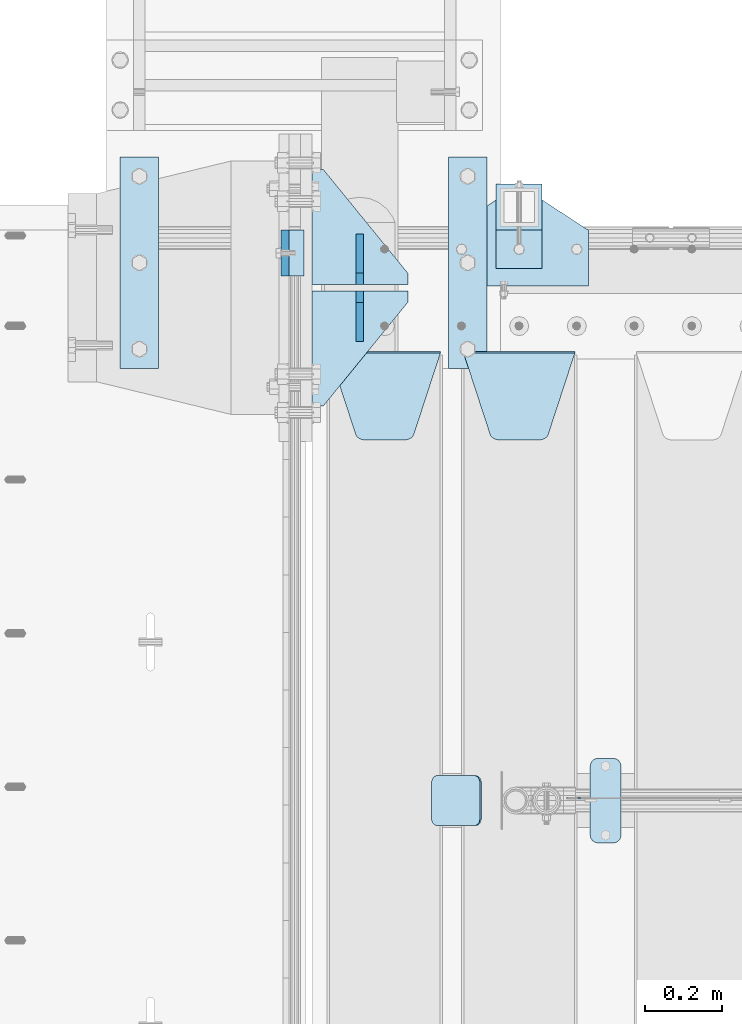
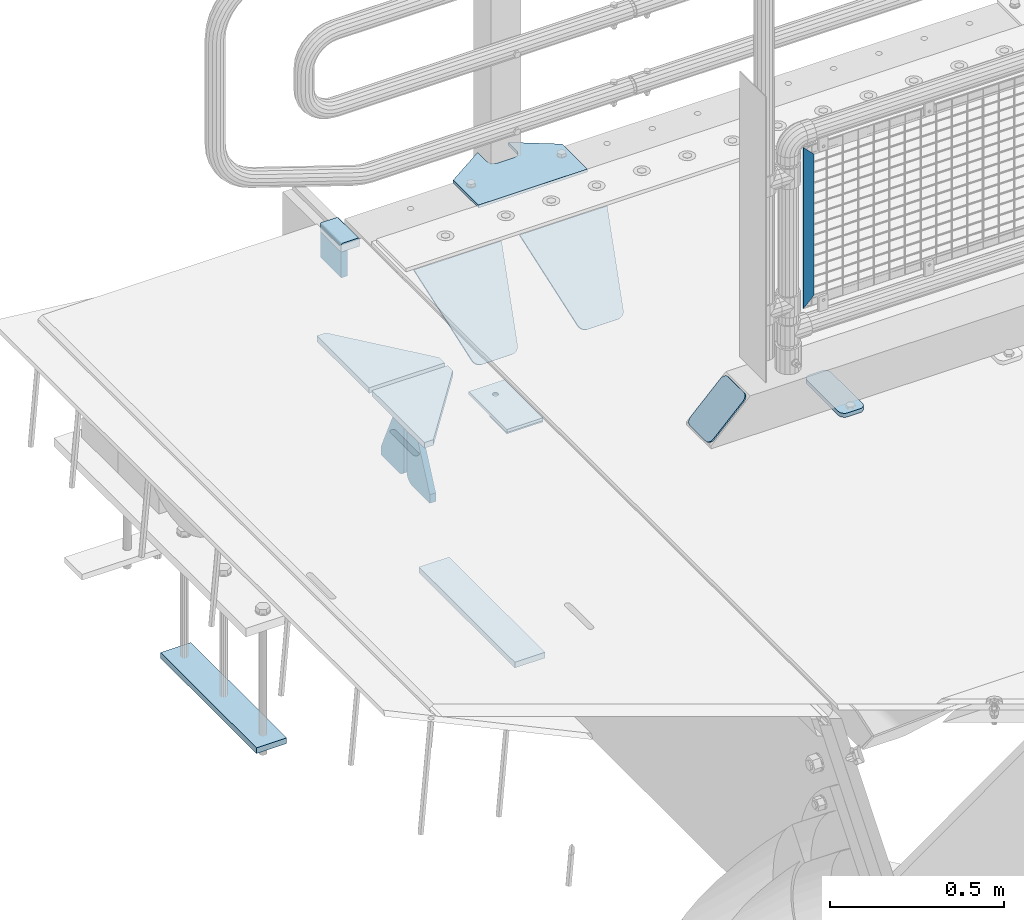
# One storey, part 193 of 219: 16 plates.
"""IFC2X3 building model written with IfcOpenShell, lengths in millimetres."""

from ifc_helpers import new_model, si_unit, frame, origin_with_axes, place, context, subcontext, project, spatial, faceted_brep, material, type_object, element, save


model = new_model("IFC2X3")

# Units and contexts
model_context = context("Model", 3, precision=1e-05, world=origin_with_axes())
body_context = subcontext(model_context, "Body", "Model", "MODEL_VIEW")
ifc_project = project(units=[si_unit("LENGTHUNIT", "METRE", prefix="MILLI"), si_unit("AREAUNIT", "SQUARE_METRE"), si_unit("VOLUMEUNIT", "CUBIC_METRE"), si_unit("MASSUNIT", "GRAM", prefix="KILO"), si_unit("TIMEUNIT", "SECOND"), si_unit("PLANEANGLEUNIT", "RADIAN"), si_unit("SOLIDANGLEUNIT", "STERADIAN"), si_unit("THERMODYNAMICTEMPERATUREUNIT", "DEGREE_CELSIUS"), si_unit("LUMINOUSINTENSITYUNIT", "LUMEN")], contexts=[model_context])

# Site, building, storey
site_placement = place(None, origin_with_axes())
site = spatial("IfcSite", under=ifc_project, at=site_placement, CompositionType="ELEMENT")
building_placement = place(site_placement, origin_with_axes())
building = spatial("IfcBuilding", under=site, at=building_placement, Name="Standard", CompositionType="ELEMENT")
storey_placement = place(building_placement, origin_with_axes())
storey = spatial("IfcBuildingStorey", under=building, at=storey_placement, Name="Undefined", CompositionType="ELEMENT", Elevation=0.0)

# Plates
ifc_material_1 = material()
plate_type_1 = type_object("IfcPlateType", PredefinedType="NOTDEFINED")
plate_1_placement = place(storey_placement, frame((-9.99999999999636, 33090.0, -16.0000571413305), z_axis=(-1.0, 0.0, 0.0), x_axis=(0.0, 0.0, 1.0)))
element("IfcPlate", 1, at=plate_1_placement, inside=storey, type_object=plate_type_1, material=ifc_material_1, context=body_context, shape_type="Brep", body=[
    faceted_brep([(0.0, -60.0, 0.0), (2.49929144047201e-09, -60.0, 60.0), (2.49929144047201e-09, 60.0000000000036, 60.0), (0.0, 60.0000000000036, 0.0), (25.0146748218828, -60.0, 60.0), (25.0146748218828, 60.0, 60.0), (26.5597449794466, -60.0, 59.7552873949117), (26.5597449794466, 60.0000000000036, 59.7552873949117), (27.9535758796897, -59.9999999999964, 59.0451032832824), (27.9535758796897, 60.0000000000036, 59.0451032832824), (29.0597323263517, -60.0, 57.9389640667317), (29.0597323263517, 60.0, 57.9389640667317), (29.7699381491534, -59.9999999999964, 56.5451442289687), (29.7699381491534, 60.0, 56.5451442289687), (30.0146748212763, -60.0, 55.0000778834025), (30.0146748212762, 60.0, 55.0000778834025), (30.0154536553013, -59.9999999999964, 5.00007788340855), (30.0154536553013, 60.0000000000036, 5.00007788340855), (29.7707554908505, -60.0, 3.45497428546548), (29.7707554908505, 60.0, 3.45497428546548), (29.0605660948355, -60.0, 2.06111154407017), (29.0605660948355, 60.0, 2.06111154407017), (27.9544051209123, -59.9999999999964, 0.954933339696428), (27.9544051209123, 60.0000000000036, 0.954933339696428), (26.5605534420796, -59.9999999999964, 0.244722232012666), (26.5605534420796, 60.0000000000036, 0.244722232012666), (25.0154536559091, -60.0, 6.05382410867605e-12), (25.0154536559091, 60.0, 6.05382410867605e-12)], [[[0, 1, 2, 3]], [[1, 4, 5, 2]], [[4, 6, 7, 5]], [[6, 8, 9, 7]], [[8, 10, 11, 9]], [[10, 12, 13, 11]], [[12, 14, 15, 13]], [[14, 16, 17, 15]], [[16, 18, 19, 17]], [[18, 20, 21, 19]], [[20, 22, 23, 21]], [[22, 24, 25, 23]], [[24, 26, 27, 25]], [[26, 0, 3, 27]], [[5, 7, 9, 11, 13, 15, 17, 19, 21, 23, 25, 27, 3, 2]], [[26, 24, 22, 20, 18, 16, 14, 12, 10, 8, 6, 4, 1, 0]]]),
])
ifc_material_2 = material(Name="STEEL/S355N")
plate_type_2 = type_object("IfcPlateType", PredefinedType="NOTDEFINED")
plate_2_placement = place(storey_placement, frame((-60.0, 33150.0000855345, -105.984391681369), z_axis=(0.0, -1.0, 0.0), x_axis=(0.0, 0.0, 1.0)))
element("IfcPlate", 2, at=plate_2_placement, inside=storey, type_object=plate_type_2, material=ifc_material_2, context=body_context, shape_type="Brep", body=[
    faceted_brep([(0.0, -10.0, 0.0), (4.30816271546064e-10, -10.0, 120.000000000004), (4.30816271546064e-10, 10.0, 120.000000000004), (0.0, 10.0, 0.0), (89.9845046997066, -10.0, 120.0), (89.9845046997066, 10.0, 120.0), (89.9843902587891, -10.0, 6.18456397205591e-11), (89.9843902587891, 10.0, 6.18456397205591e-11)], [[[0, 1, 2, 3]], [[1, 4, 5, 2]], [[4, 6, 7, 5]], [[6, 0, 3, 7]], [[5, 7, 3, 2]], [[6, 4, 1, 0]]]),
])
plate_type_3 = type_object("IfcPlateType", PredefinedType="NOTDEFINED")
plate_3_placement = place(storey_placement, frame((405.0, 32831.767766956, -1.76776695296758), z_axis=(0.0, -0.707106781186547, -0.707106781186548), x_axis=(1.0, 0.0, 0.0)))
element("IfcPlate", 3, at=plate_3_placement, inside=storey, type_object=plate_type_3, material=ifc_material_2, context=body_context, shape_type="Brep", body=[
    faceted_brep([(0.0, -2.5, 0.0), (69.345504679477, -2.5, 300.171731424834), (69.345504679477, 2.49999999999636, 300.171731424831), (0.0, 2.5, 0.0), (70.9274061199576, -2.50000000000364, 304.8974424154), (70.9274061199576, 2.49999999999636, 304.8974424154), (73.3818627772307, -2.50000000000364, 309.234538108532), (73.3818627772307, 2.49999999999636, 309.234538108532), (76.6187032999569, -2.50000000000364, 313.023683126106), (76.6187032999569, 2.49999999999636, 313.023683126106), (80.5190132704993, -2.50000000000364, 316.125672595372), (80.5190132704993, 2.49999999999636, 316.125672595372), (84.9395038596831, -2.50000000000364, 318.426546230476), (84.9395038596831, 2.5, 318.426546230479), (89.7177759439237, -2.50000000000364, 319.841774983277), (89.7177759439237, 2.5, 319.841774983281), (94.6782862926502, -2.50000000000364, 320.319366455078), (94.6782862926502, 2.49999999999636, 320.319366455078), (195.32171370735, -2.50000000000364, 320.319366455078), (195.32171370735, 2.49999999999636, 320.319366455078), (200.282224056076, -2.50000000000364, 319.841774983277), (200.282224056076, 2.5, 319.841774983281), (205.060496140317, -2.50000000000364, 318.426546230476), (205.060496140317, 2.49999999999636, 318.426546230476), (209.480986729501, -2.50000000000364, 316.125672595372), (209.480986729501, 2.49999999999636, 316.125672595372), (213.381296700043, -2.50000000000364, 313.023683126106), (213.381296700043, 2.49999999999272, 313.023683126106), (216.618137222769, -2.50000000000364, 309.234538108529), (216.618137222769, 2.49999999999636, 309.234538108525), (219.072593880042, -2.50000000000364, 304.8974424154), (219.072593880042, 2.49999999999636, 304.8974424154), (220.654495320523, -2.5, 300.171731424834), (220.654495320523, 2.49999999999636, 300.171731424831), (290.0, -2.50000000000364, 3.63797880709171e-12), (290.0, 2.49999999999636, 0.0)], [[[0, 1, 2, 3]], [[1, 4, 5, 2]], [[4, 6, 7, 5]], [[6, 8, 9, 7]], [[8, 10, 11, 9]], [[10, 12, 13, 11]], [[12, 14, 15, 13]], [[14, 16, 17, 15]], [[16, 18, 19, 17]], [[18, 20, 21, 19]], [[20, 22, 23, 21]], [[22, 24, 25, 23]], [[24, 26, 27, 25]], [[26, 28, 29, 27]], [[28, 30, 31, 29]], [[30, 32, 33, 31]], [[32, 34, 35, 33]], [[34, 0, 3, 35]], [[5, 7, 9, 11, 13, 15, 17, 19, 21, 23, 25, 27, 29, 31, 33, 35, 3, 2]], [[34, 32, 30, 28, 26, 24, 22, 20, 18, 16, 14, 12, 10, 8, 6, 4, 1, 0]]]),
])
plate_4_placement = place(storey_placement, frame((55.0, 32831.767766956, -1.76776695296758), z_axis=(0.0, -0.707106781186547, -0.707106781186548), x_axis=(1.0, 0.0, 0.0)))
element("IfcPlate", 4, at=plate_4_placement, inside=storey, type_object=plate_type_3, material=ifc_material_2, context=body_context, shape_type="Brep", body=[
    faceted_brep([(0.0, -2.5, 0.0), (69.345504679477, -2.5, 300.171731424834), (69.345504679477, 2.49999999999636, 300.171731424831), (0.0, 2.5, 0.0), (70.9274061199576, -2.50000000000364, 304.8974424154), (70.9274061199576, 2.49999999999636, 304.8974424154), (73.3818627772307, -2.50000000000364, 309.234538108532), (73.3818627772307, 2.49999999999636, 309.234538108532), (76.6187032999569, -2.50000000000364, 313.023683126106), (76.6187032999569, 2.49999999999636, 313.023683126106), (80.5190132704993, -2.50000000000364, 316.125672595372), (80.5190132704993, 2.49999999999636, 316.125672595372), (84.9395038596831, -2.50000000000364, 318.426546230476), (84.9395038596831, 2.5, 318.426546230479), (89.7177759439237, -2.50000000000364, 319.841774983277), (89.7177759439237, 2.5, 319.841774983281), (94.6782862926502, -2.50000000000364, 320.319366455078), (94.6782862926502, 2.49999999999636, 320.319366455078), (195.32171370735, -2.50000000000364, 320.319366455078), (195.32171370735, 2.49999999999636, 320.319366455078), (200.282224056076, -2.50000000000364, 319.841774983277), (200.282224056076, 2.5, 319.841774983281), (205.060496140317, -2.50000000000364, 318.426546230476), (205.060496140317, 2.49999999999636, 318.426546230476), (209.480986729501, -2.50000000000364, 316.125672595372), (209.480986729501, 2.49999999999636, 316.125672595372), (213.381296700043, -2.50000000000364, 313.023683126106), (213.381296700043, 2.49999999999272, 313.023683126106), (216.618137222769, -2.50000000000364, 309.234538108529), (216.618137222769, 2.49999999999636, 309.234538108525), (219.072593880042, -2.50000000000364, 304.8974424154), (219.072593880042, 2.49999999999636, 304.8974424154), (220.654495320523, -2.5, 300.171731424834), (220.654495320523, 2.49999999999636, 300.171731424831), (290.0, -2.50000000000364, 3.63797880709171e-12), (290.0, 2.49999999999636, 0.0)], [[[0, 1, 2, 3]], [[1, 4, 5, 2]], [[4, 6, 7, 5]], [[6, 8, 9, 7]], [[8, 10, 11, 9]], [[10, 12, 13, 11]], [[12, 14, 15, 13]], [[14, 16, 17, 15]], [[16, 18, 19, 17]], [[18, 20, 21, 19]], [[20, 22, 23, 21]], [[22, 24, 25, 23]], [[24, 26, 27, 25]], [[26, 28, 29, 27]], [[28, 30, 31, 29]], [[30, 32, 33, 31]], [[32, 34, 35, 33]], [[34, 0, 3, 35]], [[5, 7, 9, 11, 13, 15, 17, 19, 21, 23, 25, 27, 29, 31, 33, 35, 3, 2]], [[34, 32, 30, 28, 26, 24, 22, 20, 18, 16, 14, 12, 10, 8, 6, 4, 1, 0]]]),
])
ifc_material_3 = material(Name="Misc_Undefined")
plate_type_4 = type_object("IfcPlateType", PredefinedType="NOTDEFINED")
plate_5_placement = place(storey_placement, frame((709.509713540967, 31670.5, 879.519963133601), z_axis=(-0.707008801899319, 0.0, -0.707204746899291), x_axis=(-0.707204746899285, 0.0, 0.707008801899324)))
element("IfcPlate", 5, at=plate_5_placement, inside=storey, type_object=plate_type_4, material=ifc_material_3, context=body_context, shape_type="Brep", body=[
    faceted_brep([(0.0, -1.5, -5.6843418860808e-14), (-348.552185058593, -1.5, 348.655029296875), (-348.552185058593, 1.5, 348.655029296875), (0.0, 1.5, -5.6843418860808e-14), (-348.544891357421, -1.5, 398.152496337892), (-348.544891357421, 1.5, 398.152496337892), (49.5043945312482, -1.5, 7.6397554948926e-11), (49.5043945312482, 1.5, 7.6397554948926e-11)], [[[0, 1, 2, 3]], [[1, 4, 5, 2]], [[4, 6, 7, 5]], [[6, 0, 3, 7]], [[5, 7, 3, 2]], [[6, 4, 1, 0]]]),
])
plate_type_5 = type_object("IfcPlateType", PredefinedType="NOTDEFINED")
for number, where, z_axis, x_axis in (
    (6, (259.999999999996, 33008.0, -515.0), (0.0, 1.0, 0.0), (-1.0, 0.0, 0.0)),
    (7, (259.999999999996, 32992.0, -515.0), (0.0, -1.0, 0.0), (-1.0, 0.0, 0.0)),
):
    element("IfcPlate", number, at=place(storey_placement, frame(where, z_axis=z_axis, x_axis=x_axis)), inside=storey, type_object=plate_type_5, material=ifc_material_2, context=body_context, shape_type="Brep", body=[
        faceted_brep([(0.0, -10.0, 0.0), (0.0, -10.0, 30.0), (0.0, 10.0, 30.0), (0.0, 10.0, 0.0), (220.0, -10.0, 300.0), (220.0, 10.0, 300.0), (250.0, -10.0, 300.0), (250.0, 10.0, 300.0), (250.0, -10.0, 0.0), (250.0, 10.0, 0.0)], [[[0, 1, 2, 3]], [[1, 4, 5, 2]], [[4, 6, 7, 5]], [[6, 8, 9, 7]], [[8, 0, 3, 9]], [[5, 7, 9, 3, 2]], [[8, 6, 4, 1, 0]]]),
    ])
plate_type_6 = type_object("IfcPlateType", PredefinedType="NOTDEFINED")
for number, where, z_axis, x_axis in (
    (8, (135.0, 32860.0, -860.0), (0.0, 0.0, 1.0), (0.0, 1.0, 0.0)),
    (9, (135.0, 33140.0, -860.0), (0.0, 0.0, 1.0), (0.0, -1.0, 0.0)),
):
    element("IfcPlate", number, at=place(storey_placement, frame(where, z_axis=z_axis, x_axis=x_axis)), inside=storey, type_object=plate_type_6, material=ifc_material_2, context=body_context, shape_type="Brep", body=[
        faceted_brep([(0.0, -10.0, 0.0), (0.0, -10.0, 30.0), (0.0, 10.0, 30.0), (0.0, 10.0, 0.0), (102.0, -10.0, 250.0), (102.0, 10.0, 250.0), (132.0, -10.0, 250.0), (132.0, 10.0, 250.0), (132.0, -10.0, 30.0), (132.0, 10.0, 30.0), (131.544232590368, -10.0, 24.790554669992), (131.544232590368, 10.0, 24.790554669992), (130.190778623579, -10.0, 19.7393957002299), (130.190778623579, 10.0, 19.7393957002299), (127.980762113533, -10.0, 15.0), (127.980762113533, 10.0, 15.0), (124.98133329357, -10.0, 10.7163717094038), (124.98133329357, 10.0, 10.7163717094038), (121.283628290596, -10.0, 7.01866670643062), (121.283628290596, 10.0, 7.01866670643062), (117.0, -10.0, 4.01923788646684), (117.0, 10.0, 4.01923788646684), (112.260604299769, -10.0, 1.80922137642278), (112.260604299769, 10.0, 1.80922137642278), (107.209445330009, -10.0, 0.455767409633722), (107.209445330009, 10.0, 0.455767409633722), (102.0, -10.0, 0.0), (102.0, 10.0, 0.0)], [[[0, 1, 2, 3]], [[1, 4, 5, 2]], [[4, 6, 7, 5]], [[6, 8, 9, 7]], [[8, 10, 11, 9]], [[10, 12, 13, 11]], [[12, 14, 15, 13]], [[14, 16, 17, 15]], [[16, 18, 19, 17]], [[18, 20, 21, 19]], [[20, 22, 23, 21]], [[22, 24, 25, 23]], [[24, 26, 27, 25]], [[26, 0, 3, 27]], [[5, 7, 9, 11, 13, 15, 17, 19, 21, 23, 25, 27, 3, 2]], [[26, 24, 22, 20, 18, 16, 14, 12, 10, 8, 6, 4, 1, 0]]]),
    ])
ifc_material_4 = material(Name="STEEL/S355J2")
plate_type_7 = type_object("IfcPlateType", PredefinedType="NOTDEFINED")
plate_6_placement = place(storey_placement, frame((735.0, 31774.5, 21.0199999999977), z_axis=(1.0, 0.0, 0.0), x_axis=(0.0, -1.0, 0.0)))
element("IfcPlate", 10, at=plate_6_placement, inside=storey, type_object=plate_type_7, material=ifc_material_4, context=body_context, shape_type="Brep", body=[
    faceted_brep([(0.0, -7.0, 20.0), (0.0, -7.0, 60.0), (0.0, 7.0, 60.0), (0.0, 7.0, 20.0), (0.384294391937146, -7.0, 63.9018064403226), (0.384294391937146, 7.0, 63.9018064403226), (1.52240934977453, -7.0, 67.6536686473009), (1.52240934977453, 7.0, 67.6536686473009), (3.37060775395003, -7.0, 71.1114046603925), (3.37060775395003, 7.0, 71.1114046603925), (5.8578643762703, -7.0, 74.1421356237315), (5.8578643762703, 7.0, 74.1421356237315), (8.88859533960931, -7.0, 76.6293922460518), (8.88859533960931, 7.0, 76.6293922460518), (12.3463313526991, -7.0, 78.4775906502255), (12.3463313526991, 7.0, 78.4775906502255), (16.0981935596792, -7.0, 79.6157056080647), (16.0981935596792, 7.0, 79.6157056080647), (20.0, -7.0, 80.0), (20.0, 7.0, 80.0), (200.0, -7.0, 80.0), (200.0, 7.0, 80.0), (203.901806440321, -7.0, 79.6157056080647), (203.901806440321, 7.0, 79.6157056080647), (207.653668647301, -7.0, 78.4775906502255), (207.653668647301, 7.0, 78.4775906502255), (211.111404660391, -7.0, 76.6293922460518), (211.111404660391, 7.0, 76.6293922460518), (214.14213562373, -7.0, 74.1421356237315), (214.14213562373, 7.0, 74.1421356237315), (216.62939224605, -7.0, 71.1114046603925), (216.62939224605, 7.0, 71.1114046603925), (218.477590650225, -7.0, 67.6536686473009), (218.477590650225, 7.0, 67.6536686473009), (219.615705608063, -7.0, 63.9018064403226), (219.615705608063, 7.0, 63.9018064403226), (220.0, -7.0, 60.0), (220.0, 7.0, 60.0), (220.0, -7.0, 20.0), (220.0, 7.0, 20.0), (219.615705608063, -7.0, 16.0981935596774), (219.615705608063, 7.0, 16.0981935596774), (218.477590650225, -7.0, 12.3463313526991), (218.477590650225, 7.0, 12.3463313526991), (216.62939224605, -7.0, 8.88859533960749), (216.62939224605, 7.0, 8.88859533960749), (214.14213562373, -7.0, 5.85786437626848), (214.14213562373, 7.0, 5.85786437626848), (211.111404660391, -7.0, 3.37060775394821), (211.111404660391, 7.0, 3.37060775394821), (207.653668647301, -7.0, 1.52240934977453), (207.653668647301, 7.0, 1.52240934977453), (203.901806440321, -7.0, 0.384294391935327), (203.901806440321, 7.0, 0.384294391935327), (200.0, -7.0, 0.0), (200.0, 7.0, 0.0), (20.0, -7.0, 0.0), (20.0, 7.0, 0.0), (16.0981935596792, -7.0, 0.384294391935327), (16.0981935596792, 7.0, 0.384294391935327), (12.3463313526991, -7.0, 1.52240934977453), (12.3463313526991, 7.0, 1.52240934977453), (8.88859533960931, -7.0, 3.37060775394821), (8.88859533960931, 7.0, 3.37060775394821), (5.8578643762703, -7.0, 5.85786437626848), (5.8578643762703, 7.0, 5.85786437626848), (3.37060775395003, -7.0, 8.88859533960749), (3.37060775395003, 7.0, 8.88859533960749), (1.52240934977453, -7.0, 12.3463313526991), (1.52240934977453, 7.0, 12.3463313526991), (0.384294391937146, -7.0, 16.0981935596774), (0.384294391937146, 7.0, 16.0981935596774)], [[[0, 1, 2, 3]], [[1, 4, 5, 2]], [[4, 6, 7, 5]], [[6, 8, 9, 7]], [[8, 10, 11, 9]], [[10, 12, 13, 11]], [[12, 14, 15, 13]], [[14, 16, 17, 15]], [[16, 18, 19, 17]], [[18, 20, 21, 19]], [[20, 22, 23, 21]], [[22, 24, 25, 23]], [[24, 26, 27, 25]], [[26, 28, 29, 27]], [[28, 30, 31, 29]], [[30, 32, 33, 31]], [[32, 34, 35, 33]], [[34, 36, 37, 35]], [[36, 38, 39, 37]], [[38, 40, 41, 39]], [[40, 42, 43, 41]], [[42, 44, 45, 43]], [[44, 46, 47, 45]], [[46, 48, 49, 47]], [[48, 50, 51, 49]], [[50, 52, 53, 51]], [[52, 54, 55, 53]], [[54, 56, 57, 55]], [[56, 58, 59, 57]], [[58, 60, 61, 59]], [[60, 62, 63, 61]], [[62, 64, 65, 63]], [[64, 66, 67, 65]], [[66, 68, 69, 67]], [[68, 70, 71, 69]], [[70, 0, 3, 71]], [[5, 7, 9, 11, 13, 15, 17, 19, 21, 23, 25, 27, 29, 31, 33, 35, 37, 39, 41, 43, 45, 47, 49, 51, 53, 55, 57, 59, 61, 63, 65, 67, 69, 71, 3, 2]], [[70, 68, 66, 64, 62, 60, 58, 56, 54, 52, 50, 48, 46, 44, 42, 40, 38, 36, 34, 32, 30, 28, 26, 24, 22, 20, 18, 16, 14, 12, 10, 8, 6, 4, 1, 0]]]),
])
plate_type_8 = type_object("IfcPlateType", PredefinedType="NOTDEFINED")
plate_7_placement = place(storey_placement, frame((449.80758152104, 31729.5, 166.254400376568), z_axis=(-0.707410512925777, 0.0, -0.706802918925841), x_axis=(0.0, -1.0, 0.0)))
element("IfcPlate", 11, at=plate_7_placement, inside=storey, type_object=plate_type_8, material=ifc_material_4, context=body_context, shape_type="Brep", body=[
    faceted_brep([(0.0, -2.5, 20.0), (0.0, -2.5, 158.926651000977), (0.0, 2.5, 158.926651000977), (0.0, 2.49999999999818, 20.0), (0.384294391937146, -2.5, 162.828457441299), (0.384294391937146, 2.5, 162.828457441299), (1.52240934977453, -2.5, 166.580319648279), (1.52240934977453, 2.5, 166.580319648279), (3.37060775395003, -2.5, 170.038055661367), (3.37060775395003, 2.5, 170.038055661367), (5.8578643762703, -2.5, 173.068786624706), (5.8578643762703, 2.5, 173.068786624706), (8.88859533960931, -2.5, 175.556043247028), (8.88859533960931, 2.5, 175.556043247027), (12.3463313526991, -2.49999999999818, 177.404241651202), (12.3463313526991, 2.5, 177.404241651202), (16.0981935596792, -2.5, 178.542356609041), (16.0981935596792, 2.5, 178.542356609041), (20.0, -2.5, 178.926651000977), (20.0, 2.5, 178.926651000975), (110.0, -2.5, 178.926651000977), (110.0, 2.5, 178.926651000975), (113.901806440321, -2.5, 178.542356609041), (113.901806440321, 2.5, 178.542356609041), (117.653668647301, -2.49999999999818, 177.404241651202), (117.653668647301, 2.5, 177.404241651202), (121.111404660391, -2.5, 175.556043247028), (121.111404660391, 2.5, 175.556043247027), (124.14213562373, -2.5, 173.068786624706), (124.14213562373, 2.5, 173.068786624706), (126.62939224605, -2.5, 170.038055661367), (126.62939224605, 2.5, 170.038055661367), (128.477590650225, -2.5, 166.580319648279), (128.477590650225, 2.5, 166.580319648279), (129.615705608063, -2.5, 162.828457441299), (129.615705608063, 2.5, 162.828457441299), (130.0, -2.5, 158.926651000977), (130.0, 2.5, 158.926651000977), (130.0, -2.5, 20.0), (130.0, 2.49999999999818, 20.0), (129.615705608063, -2.50000000000182, 16.0981935596774), (129.615705608063, 2.50000000000182, 16.0981935596774), (128.477590650225, -2.5, 12.3463313526972), (128.477590650225, 2.5, 12.3463313526991), (126.62939224605, -2.5, 8.88859533960749), (126.62939224605, 2.50000000000182, 8.88859533960749), (124.14213562373, -2.50000000000182, 5.85786437626848), (124.14213562373, 2.5, 5.85786437626848), (121.111404660391, -2.5, 3.37060775394821), (121.111404660391, 2.5, 3.37060775395003), (117.653668647301, -2.5, 1.52240934977453), (117.653668647301, 2.5, 1.52240934977272), (113.901806440321, -2.5, 0.384294391935327), (113.901806440321, 2.5, 0.384294391935327), (110.0, -2.5, -1.81898940354586e-12), (110.0, 2.49999999999818, 0.0), (20.0, -2.5, -1.81898940354586e-12), (20.0, 2.49999999999818, 0.0), (16.0981935596792, -2.5, 0.384294391935327), (16.0981935596792, 2.5, 0.384294391935327), (12.3463313526991, -2.5, 1.52240934977453), (12.3463313526991, 2.5, 1.52240934977272), (8.88859533960931, -2.5, 3.37060775394821), (8.88859533960931, 2.5, 3.37060775395003), (5.8578643762703, -2.50000000000182, 5.85786437626848), (5.8578643762703, 2.5, 5.85786437626848), (3.37060775395003, -2.5, 8.88859533960749), (3.37060775395003, 2.50000000000182, 8.88859533960749), (1.52240934977453, -2.5, 12.3463313526972), (1.52240934977453, 2.5, 12.3463313526991), (0.384294391937146, -2.50000000000182, 16.0981935596774), (0.384294391937146, 2.50000000000182, 16.0981935596774)], [[[0, 1, 2, 3]], [[1, 4, 5, 2]], [[4, 6, 7, 5]], [[6, 8, 9, 7]], [[8, 10, 11, 9]], [[10, 12, 13, 11]], [[12, 14, 15, 13]], [[14, 16, 17, 15]], [[16, 18, 19, 17]], [[18, 20, 21, 19]], [[20, 22, 23, 21]], [[22, 24, 25, 23]], [[24, 26, 27, 25]], [[26, 28, 29, 27]], [[28, 30, 31, 29]], [[30, 32, 33, 31]], [[32, 34, 35, 33]], [[34, 36, 37, 35]], [[36, 38, 39, 37]], [[38, 40, 41, 39]], [[40, 42, 43, 41]], [[42, 44, 45, 43]], [[44, 46, 47, 45]], [[46, 48, 49, 47]], [[48, 50, 51, 49]], [[50, 52, 53, 51]], [[52, 54, 55, 53]], [[54, 56, 57, 55]], [[56, 58, 59, 57]], [[58, 60, 61, 59]], [[60, 62, 63, 61]], [[62, 64, 65, 63]], [[64, 66, 67, 65]], [[66, 68, 69, 67]], [[68, 70, 71, 69]], [[70, 0, 3, 71]], [[5, 7, 9, 11, 13, 15, 17, 19, 21, 23, 25, 27, 29, 31, 33, 35, 37, 39, 41, 43, 45, 47, 49, 51, 53, 55, 57, 59, 61, 63, 65, 67, 69, 71, 3, 2]], [[70, 68, 66, 64, 62, 60, 58, 56, 54, 52, 50, 48, 46, 44, 42, 40, 38, 36, 34, 32, 30, 28, 26, 24, 22, 20, 18, 16, 14, 12, 10, 8, 6, 4, 1, 0]]]),
])
plate_type_9 = type_object("IfcPlateType", PredefinedType="NOTDEFINED")
plate_8_placement = place(storey_placement, frame((370.0, 33005.0, 5.00000000004911), z_axis=(0.0, 1.0, 0.0), x_axis=(1.0, 0.0, 0.0)))
element("IfcPlate", 12, at=plate_8_placement, inside=storey, type_object=plate_type_9, material=ifc_material_4, context=body_context, shape_type="Brep", body=[
    faceted_brep([(0.0, -5.0, 0.0), (2.31396552408114e-06, -5.0, 145.0), (2.31396552408114e-06, 5.0, 145.0), (0.0, 5.0, 0.0), (130.0, -5.0, 230.0), (130.0, 5.0, 230.0), (130.0, -5.0, 180.0), (130.0, 5.0, 180.0), (130.48036798992, -5.0, 175.122741949599), (130.48036798992, 5.0, 175.122741949599), (131.903011687218, -5.0, 170.432914190875), (131.903011687218, 5.0, 170.432914190875), (134.213259692437, -5.0, 166.110744174512), (134.213259692437, 5.0, 166.110744174512), (137.322330470337, -5.0, 162.322330470335), (137.322330470337, 5.0, 162.322330470335), (141.11074417451, -5.0, 159.213259692435), (141.11074417451, 5.0, 159.213259692435), (145.432914190873, -5.0, 156.903011687216), (145.432914190873, 5.0, 156.903011687216), (150.122741949597, -5.0, 155.48036798992), (150.122741949597, 5.0, 155.48036798992), (155.0, -5.0, 155.0), (155.0, 5.0, 155.0), (205.0, -5.0, 155.0), (205.0, 5.0, 155.0), (209.877258050403, -5.0, 155.48036798992), (209.877258050403, 5.0, 155.48036798992), (214.567085809127, -5.0, 156.903011687216), (214.567085809127, 5.0, 156.903011687216), (218.88925582549, -5.0, 159.213259692435), (218.88925582549, 5.0, 159.213259692435), (222.677669529663, -5.0, 162.322330470335), (222.677669529663, 5.0, 162.322330470335), (225.786740307563, -5.0, 166.110744174512), (225.786740307563, 5.0, 166.110744174512), (228.096988312782, -5.0, 170.432914190875), (228.096988312782, 5.0, 170.432914190875), (229.51963201008, -5.0, 175.122741949599), (229.51963201008, 5.0, 175.122741949599), (230.0, -5.0, 180.0), (230.0, 5.0, 180.0), (230.0, -5.0, 230.0), (230.0, 5.0, 230.0), (360.0, -5.0, 145.0), (360.0, 5.0, 145.0), (360.0, -5.0, -7.27595761418343e-12), (360.0, 5.0, -7.27595761418343e-12)], [[[0, 1, 2, 3]], [[1, 4, 5, 2]], [[4, 6, 7, 5]], [[6, 8, 9, 7]], [[8, 10, 11, 9]], [[10, 12, 13, 11]], [[12, 14, 15, 13]], [[14, 16, 17, 15]], [[16, 18, 19, 17]], [[18, 20, 21, 19]], [[20, 22, 23, 21]], [[22, 24, 25, 23]], [[24, 26, 27, 25]], [[26, 28, 29, 27]], [[28, 30, 31, 29]], [[30, 32, 33, 31]], [[32, 34, 35, 33]], [[34, 36, 37, 35]], [[36, 38, 39, 37]], [[38, 40, 41, 39]], [[40, 42, 43, 41]], [[42, 44, 45, 43]], [[44, 46, 47, 45]], [[46, 0, 3, 47]], [[5, 7, 9, 11, 13, 15, 17, 19, 21, 23, 25, 27, 29, 31, 33, 35, 37, 39, 41, 43, 45, 47, 3, 2]], [[46, 44, 42, 40, 38, 36, 34, 32, 30, 28, 26, 24, 22, 20, 18, 16, 14, 12, 10, 8, 6, 4, 1, 0]]]),
])
plate_type_10 = type_object("IfcPlateType", PredefinedType="NOTDEFINED")
plate_9_placement = place(storey_placement, frame((490.000000000138, 33050.0000000002, -850.000000000002), z_axis=(0.0, 1.0, 0.0), x_axis=(1.0, 0.0, 0.0)))
element("IfcPlate", 13, at=plate_9_placement, inside=storey, type_object=plate_type_10, material=ifc_material_4, context=body_context, shape_type="Brep", body=[
    faceted_brep([(66.3639610305399, -5.0, 163.636038969111), (66.3639610305399, 5.0, 163.636038969111), (59.9999999998618, 5.0, 160.999999999789), (59.9999999998618, -5.0, 160.999999999789), (53.6360389691836, 5.0, 163.636038969111), (53.6360389691836, -5.0, 163.636038969111), (50.9999999998618, 5.0, 169.999999999789), (50.9999999998618, -5.0, 169.999999999789), (53.6360389691836, 5.0, 176.363961030467), (53.6360389691836, -5.0, 176.363961030467), (59.9999999998618, 5.0, 178.999999999789), (59.9999999998618, -5.0, 178.999999999789), (66.3639610305399, 5.0, 176.363961030467), (66.3639610305399, -5.0, 176.363961030467), (68.9999999998618, 5.0, 169.999999999789), (68.9999999998618, -5.0, 169.999999999789), (120.0, -5.0, 0.0), (120.0, -5.0, 220.0), (0.0, -5.0, 220.0), (0.0, -5.0, 0.0), (0.0, 5.0, 0.0), (120.0, 5.0, 0.0), (120.0, 5.0, 220.0), (0.0, 5.0, 220.0)], [[[0, 1, 2, 3]], [[3, 2, 4, 5]], [[5, 4, 6, 7]], [[7, 6, 8, 9]], [[9, 8, 10, 11]], [[11, 10, 12, 13]], [[13, 12, 14, 15]], [[15, 14, 1, 0]], [[16, 17, 18, 19], [3, 5, 7, 9, 11, 13, 15, 0]], [[16, 19, 20, 21]], [[17, 16, 21, 22]], [[18, 17, 22, 23]], [[19, 18, 23, 20]], [[22, 21, 20, 23], [10, 8, 6, 4, 2, 1, 14, 12]]]),
])
plate_type_11 = type_object("IfcPlateType", PredefinedType="NOTDEFINED")
plate_10_placement = place(storey_placement, frame((490.000000000138, 33050.0000000002, -857.500000000002), z_axis=(0.0, 1.0, 0.0), x_axis=(1.0, 0.0, 0.0)))
element("IfcPlate", 14, at=plate_10_placement, inside=storey, type_object=plate_type_11, material=ifc_material_4, context=body_context, shape_type="Brep", body=[
    faceted_brep([(0.0, -2.5, 0.0), (0.0, -2.5, 100.0), (0.0, 2.5, 100.0), (0.0, 2.5, 0.0), (120.0, -2.5, 100.0), (120.0, 2.5, 100.0), (120.0, -2.5, 0.0), (120.0, 2.5, 0.0)], [[[0, 1, 2, 3]], [[1, 4, 5, 2]], [[4, 6, 7, 5]], [[6, 0, 3, 7]], [[5, 7, 3, 2]], [[6, 4, 1, 0]]]),
])
plate_type_12 = type_object("IfcPlateType", PredefinedType="NOTDEFINED")
for number, where, z_axis, x_axis in (
    (15, (-488.999999999987, 33339.9999985338, -1468.0), (0.0, -1.0, 0.0), (1.0, 0.0, 0.0)),
    (16, (366.000000000013, 33339.9999985338, -1468.0), (0.0, -1.0, 0.0), (1.0, 0.0, 0.0)),
):
    element("IfcPlate", number, at=place(storey_placement, frame(where, z_axis=z_axis, x_axis=x_axis)), inside=storey, type_object=plate_type_12, material=ifc_material_2, context=body_context, shape_type="Brep", body=[
        faceted_brep([(0.0, -10.0, 0.0), (1.00943179859314e-06, -10.0, 550.0), (1.00943179859314e-06, 10.0, 550.0), (0.0, 10.0, 0.0), (100.0, -10.0, 550.0), (100.0, 10.0, 550.0), (100.0, -10.0, 0.0), (100.0, 10.0, 0.0)], [[[0, 1, 2, 3]], [[1, 4, 5, 2]], [[4, 6, 7, 5]], [[6, 0, 3, 7]], [[5, 7, 3, 2]], [[6, 4, 1, 0]]]),
    ])

save(model, "model.ifc")
